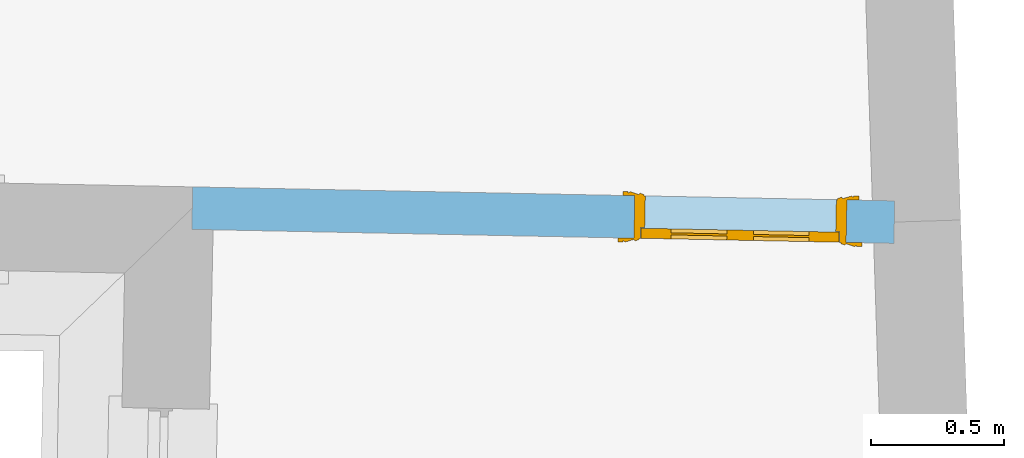
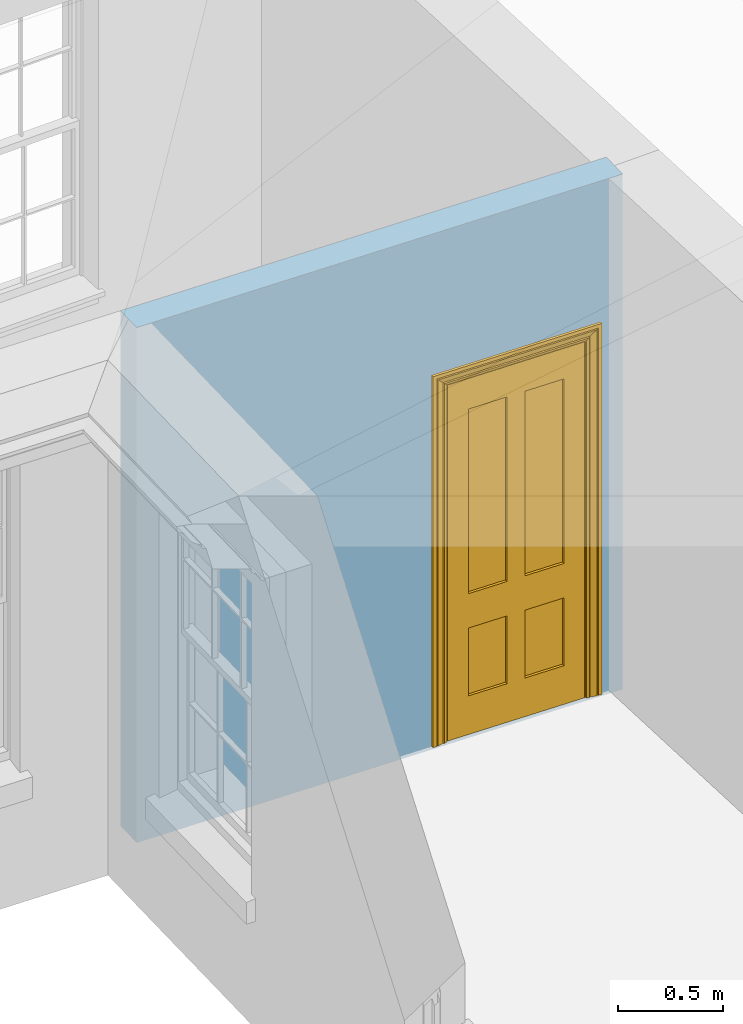
# One storey, part 6 of 11: 1 door, 1 opening, plus 1 element that does not belong to this part.
"""IFC2X3 building model written with IfcOpenShell, lengths in metres."""

import ifcopenshell
import ifcopenshell.guid

model = None  # the IFC model being written
_history = None  # IfcOwnerHistory: only IFC2X3 demands one
_inside = {}  # id of a spatial element -> (the spatial element, [elements in it])
_under = {}  # id of a project, library or spatial element -> (it, [spatial elements below it])
_declared = {}  # id of a project -> (the project, [libraries it declares])
_typed = {}  # id of a type object -> (the type object, [elements of that type])
_made_of = {}  # id of a material, layer set ... -> (it, [elements and type objects made of it])


def new_model(schema):
    """Start an empty IFC model of exactly this schema.

    Asked for "IFC4X3", IfcOpenShell would pick the latest addendum, in which some entities
    have other attributes; the version numbers below select the first issue.
    IFC2X3 requires an IfcOwnerHistory on every rooted entity: one is made here for all.
    """
    global model, _history
    if schema == "IFC4X3":
        model = ifcopenshell.file(schema_version=(4, 3, 0, 0))
    else:
        model = ifcopenshell.file(schema=schema)
    _inside.clear()
    _under.clear()
    _declared.clear()
    _typed.clear()
    _made_of.clear()
    _history = None
    if model.schema == "IFC2X3":
        org = make("IfcOrganization", Name="unknown")
        user = make(
            "IfcPersonAndOrganization",
            ThePerson=make("IfcPerson", FamilyName="unknown"),
            TheOrganization=org,
        )
        app = make(
            "IfcApplication",
            ApplicationDeveloper=org,
            Version="unknown",
            ApplicationFullName="unknown",
            ApplicationIdentifier="unknown",
        )
        _history = make(
            "IfcOwnerHistory",
            OwningUser=user,
            OwningApplication=app,
            ChangeAction="ADDED",
            CreationDate=0,
        )
    return model


def make(cls, **values):
    """One entity of the class cls with the attributes given. An attribute that is None is left unset."""
    return model.create_entity(
        cls, **{name: value for name, value in values.items() if value is not None}
    )


def rooted(cls, **values):
    """An entity with a GlobalId (a new one), such as an element, a storey or a relation."""
    return make(cls, GlobalId=ifcopenshell.guid.new(), OwnerHistory=_history, **values)


def si_unit(unit_type, name, prefix=None):
    """IfcSIUnit, for example si_unit("LENGTHUNIT", "METRE", prefix="MILLI")."""
    return make("IfcSIUnit", UnitType=unit_type, Prefix=prefix, Name=name)


def assignment(units):
    """IfcUnitAssignment: the units of a project."""
    return None if units is None else make("IfcUnitAssignment", Units=units)


def point(xyz):
    """IfcCartesianPoint."""
    return None if xyz is None else make("IfcCartesianPoint", Coordinates=xyz)


def direction(xyz):
    """IfcDirection."""
    return None if xyz is None else make("IfcDirection", DirectionRatios=xyz)


def frame(location, z_axis=None, x_axis=None):
    """IfcAxis2Placement3D, a coordinate frame: its origin and axes. An axis left out is left unset."""
    return make(
        "IfcAxis2Placement3D",
        Location=point(location),
        Axis=direction(z_axis),
        RefDirection=direction(x_axis),
    )


def origin():
    """The frame at (0, 0, 0) with its axes left unset."""
    return frame((0.0, 0.0, 0.0))


def place(relative_to, where):
    """IfcLocalPlacement: puts the frame where relative to a parent placement (None: the world)."""
    return make(
        "IfcLocalPlacement", PlacementRelTo=relative_to, RelativePlacement=where
    )


def context(
    kind, dimensions, precision=None, world=None, true_north=None, identifier=None
):
    """IfcGeometricRepresentationContext, for example the 3D "Model" context."""
    return make(
        "IfcGeometricRepresentationContext",
        ContextIdentifier=identifier,
        ContextType=kind,
        CoordinateSpaceDimension=dimensions,
        Precision=precision,
        WorldCoordinateSystem=world,
        TrueNorth=true_north,
    )


def subcontext(parent, identifier, kind, view, scale=None):
    """IfcGeometricRepresentationSubContext, for example "Body" below "Model"."""
    return make(
        "IfcGeometricRepresentationSubContext",
        ContextIdentifier=identifier,
        ContextType=kind,
        ParentContext=parent,
        TargetScale=scale,
        TargetView=view,
    )


def project(units=None, contexts=None):
    """IfcProject with its units and contexts."""
    return rooted(
        "IfcProject",
        Name="project",
        RepresentationContexts=contexts,
        UnitsInContext=assignment(units),
    )


def spatial(cls, under=None, at=None, **own):
    """A site, building, storey or space (cls), placed at a placement, below another one or the project."""
    s = rooted(cls, ObjectPlacement=at, **own)
    if under is not None:
        _under.setdefault(under.id(), (under, []))[1].append(s)
    return s


def polyline(points):
    """IfcPolyline through the points."""
    return make("IfcPolyline", Points=[point(p) for p in points])


def outline(outer, holes=None, kind="AREA"):
    """IfcArbitraryClosedProfileDef: a profile drawn as a closed curve; with holes, ...WithVoids."""
    if holes is None:
        return make("IfcArbitraryClosedProfileDef", ProfileType=kind, OuterCurve=outer)
    return make(
        "IfcArbitraryProfileDefWithVoids",
        ProfileType=kind,
        OuterCurve=outer,
        InnerCurves=holes,
    )


def extrude(swept, where, along, depth):
    """IfcExtrudedAreaSolid: the profile swept, set in the frame where, extruded along a direction by depth."""
    return make(
        "IfcExtrudedAreaSolid",
        SweptArea=swept,
        Position=where,
        ExtrudedDirection=direction(along),
        Depth=depth,
    )


def faces_of(points, faces, orient=None, outer=None):
    """IfcFace entities. A face is a list of loops; a loop is a list of indices into points, from 0.

    orient and outer hold one flag for each loop. By default every Orientation is true, the
    first loop of a face is its IfcFaceOuterBound and the others are IfcFaceBound.
    """
    made = []
    for i, loops in enumerate(faces):
        bounds = []
        for j, loop in enumerate(loops):
            is_outer = j == 0 if outer is None else outer[i][j]
            bounds.append(
                make(
                    "IfcFaceOuterBound" if is_outer else "IfcFaceBound",
                    Bound=make("IfcPolyLoop", Polygon=[points[k] for k in loop]),
                    Orientation=True if orient is None else orient[i][j],
                )
            )
        made.append(make("IfcFace", Bounds=bounds))
    return made


def faceted_brep(points, faces, orient=None, outer=None, voids=None):
    """IfcFacetedBrep: a solid bounded by flat faces; with voids (closed shells), ...WithVoids."""
    shared = [point(p) for p in points]
    hull = make("IfcClosedShell", CfsFaces=faces_of(shared, faces, orient, outer))
    if voids is None:
        return make("IfcFacetedBrep", Outer=hull)
    return make(
        "IfcFacetedBrepWithVoids",
        Outer=hull,
        Voids=[
            make(cls, CfsFaces=faces_of(shared, fs, o, b)) for cls, fs, o, b in voids
        ],
    )


def shape(context_of_items, identifier, shape_type, items):
    """IfcShapeRepresentation: the items that make up one representation, for example the "Body"."""
    return make(
        "IfcShapeRepresentation",
        ContextOfItems=context_of_items,
        RepresentationIdentifier=identifier,
        RepresentationType=shape_type,
        Items=items,
    )


def material(Name=None, Category=None):
    """IfcMaterial."""
    return make("IfcMaterial", Name=Name, Category=Category)


def layer(
    of_material, thickness, ventilated=None, Name=None, Category=None, Priority=None
):
    """IfcMaterialLayer: one layer of a wall or slab, of a material (None: an air gap)."""
    return make(
        "IfcMaterialLayer",
        Material=of_material,
        LayerThickness=thickness,
        IsVentilated=ventilated,
        Name=Name,
        Category=Category,
        Priority=Priority,
    )


def layer_set(layers, Name=None):
    """IfcMaterialLayerSet."""
    return make("IfcMaterialLayerSet", MaterialLayers=layers, LayerSetName=Name)


def layer_usage(for_layer_set, set_direction, sense, offset, extent=None):
    """IfcMaterialLayerSetUsage: how a layer set lies in its element."""
    return make(
        "IfcMaterialLayerSetUsage",
        ForLayerSet=for_layer_set,
        LayerSetDirection=set_direction,
        DirectionSense=sense,
        OffsetFromReferenceLine=offset,
        ReferenceExtent=extent,
    )


def made_of(thing, what):
    """Note that an element or type object is made of a material, layer set ...; save() writes the relation."""
    if what is not None:
        _made_of.setdefault(what.id(), (what, []))[1].append(thing)
    return thing


def element(
    cls,
    number,
    at=None,
    inside=None,
    cuts=None,
    type_object=None,
    material=None,
    context=None,
    identifier="Body",
    shape_type=None,
    held_by="IfcProductDefinitionShape",
    body=None,
    shapes=None,
    **own,
):
    """One element of the class cls, such as IfcWall. Its Tag is "e" and its number.

    at: its placement. inside: the storey or other place that contains it. cuts: it is an
    opening in that element (IfcRelVoidsElement). A single representation is given by context,
    identifier, shape_type and body (its items); several are given by shapes. held_by: the class
    of the entity that holds the representations. save() writes the other relations.
    """
    e = rooted(cls, Tag="e%d" % number, ObjectPlacement=at, **own)
    if body is not None:
        shapes = [shape(context, identifier, shape_type, body)]
    if shapes is not None:
        e.Representation = make(held_by, Representations=shapes)
    if inside is not None:
        _inside.setdefault(inside.id(), (inside, []))[1].append(e)
    if cuts is not None:
        rooted(
            "IfcRelVoidsElement", RelatingBuildingElement=cuts, RelatedOpeningElement=e
        )
    if type_object is not None:
        _typed.setdefault(type_object.id(), (type_object, []))[1].append(e)
    return made_of(e, material)


def fill(opening, filler):
    """IfcRelFillsElement: the door or window that sits in an opening."""
    return rooted(
        "IfcRelFillsElement",
        RelatingOpeningElement=opening,
        RelatedBuildingElement=filler,
    )


def aggregate(whole, parts):
    """IfcRelAggregates: a whole, such as a stair, and the parts it consists of."""
    return rooted("IfcRelAggregates", RelatingObject=whole, RelatedObjects=parts)


def save(model, path):
    """Write the relations noted so far, then the file.

    IfcRelAggregates (storeys below a building ...), IfcRelContainedInSpatialStructure (elements
    in a storey), IfcRelDefinesByType, IfcRelAssociatesMaterial and IfcRelDeclares: one each for
    every whole, place, type object, material and project.
    """
    for whole, parts in _under.values():
        aggregate(whole, parts)
    for where, things in _inside.values():
        rooted(
            "IfcRelContainedInSpatialStructure",
            RelatedElements=things,
            RelatingStructure=where,
        )
    for kind, things in _typed.values():
        rooted("IfcRelDefinesByType", RelatedObjects=things, RelatingType=kind)
    for what, things in _made_of.values():
        rooted("IfcRelAssociatesMaterial", RelatedObjects=things, RelatingMaterial=what)
    for by, libraries in _declared.values():
        rooted("IfcRelDeclares", RelatingContext=by, RelatedDefinitions=libraries)
    model.write(path)


model = new_model("IFC2X3")

# Units and contexts
model_context = context("Model", 3, world=origin())
body_context = subcontext(model_context, "Body", "Model", "MODEL_VIEW")
ifc_project = project(units=[si_unit("PLANEANGLEUNIT", "RADIAN"), si_unit("MASSUNIT", "GRAM", prefix="KILO"), si_unit("FORCEUNIT", "NEWTON", prefix="KILO"), si_unit("LENGTHUNIT", "METRE")], contexts=[model_context])

# Site, building, storey
site_placement = place(None, origin())
site = spatial("IfcSite", under=ifc_project, at=site_placement, CompositionType="ELEMENT")
building_placement = place(None, origin())
building = spatial("IfcBuilding", under=site, at=building_placement, Name="Building plot-10", CompositionType="ELEMENT")
storey_placement = place(None, frame((0.0, 0.0, 4.6)))
storey = spatial("IfcBuildingStorey", under=building, at=storey_placement, Name="Floor 1", CompositionType="ELEMENT", Elevation=4.6)

# Wall, opening, door
ifc_material = material(Name="Masonry")
ifc_layer = layer(ifc_material, 0.16, ventilated=False)
ifc_layer_set = layer_set([ifc_layer], Name="My Wall")
ifc_layer_usage = layer_usage(ifc_layer_set, "AXIS2", "NEGATIVE", 0.08)
wall_placement = place(storey_placement, origin())
wall = element("IfcWallStandardCase", 1, at=wall_placement, inside=storey, material=ifc_layer_usage, Name="interior", context=body_context, shape_type="SweptSolid", body=[
    extrude(outline(polyline([(53.5679253721729, 17.0442968217982), (53.5711131476829, 17.204265062669), (50.9254174036142, 17.2569873033702), (50.9222296281042, 17.0970190624994), (53.5679253721729, 17.0442968217982)])), origin(), (0.0, 0.0, 1.0), 3.0),
])
opening_placement = place(storey_placement, frame((0.0, 0.0, 0.0199999999999996)))
opening = element("IfcOpeningElement", 2, at=opening_placement, cuts=wall, Name="Opening", ObjectType="Opening", context=body_context, shape_type="SweptSolid", body=[
    extrude(outline(polyline([(53.3911488767032, 17.2078513101177), (52.5913076723492, 17.2237901876675), (52.5881198968393, 17.0638219467967), (53.3879611011933, 17.0478830692469), (53.3911488767032, 17.2078513101177)])), origin(), (0.0, 0.0, 1.0), 2.1),
])
door_placement = place(storey_placement, frame((53.3895549889482, 17.1278671896823, 0.0199999999999996), z_axis=(0.0, 0.0, 1.0), x_axis=(-0.799841204353996, 0.0159388775497824, 0.0)))
door = element("IfcDoor", 3, at=door_placement, inside=storey, Name="toilet inside door", OverallHeight=2.1, OverallWidth=0.8, context=body_context, shape_type="Brep", held_by="IfcProductRepresentation", body=[
    faceted_brep([(0.773, 0.08, 1.895), (0.66, 0.08, 1.895), (0.66, 0.08, 2.073), (0.773, 0.08, 2.073), (0.773, 0.08, 0.82), (0.66, 0.08, 0.82), (0.45, 0.08, 1.895), (0.45, 0.08, 2.073), (0.773, 0.08, 0.62), (0.66, 0.08, 0.62), (0.66, 0.065, 0.82), (0.66, 0.065, 1.895), (0.45, 0.065, 1.895), (0.35, 0.08, 1.895), (0.35, 0.08, 2.073), (0.773, 0.08, 0.225), (0.66, 0.08, 0.225), (0.45, 0.08, 0.62), (0.45, 0.08, 0.82), (0.45, 0.065, 0.82), (0.35, 0.08, 0.82), (0.14, 0.08, 2.073), (0.14, 0.08, 1.895), (0.773, 0.08, 0.0), (0.66, 0.08, 0.0), (0.66, 0.065, 0.225), (0.66, 0.065, 0.62), (0.45, 0.065, 0.62), (0.35, 0.08, 0.62), (0.35, 0.065, 0.82), (0.35, 0.065, 1.895), (0.14, 0.065, 1.895), (0.027, 0.08, 2.073), (0.027, 0.08, 1.895), (0.773, 0.042, 0.0), (0.66, 0.042, 0.0), (0.45, 0.08, 0.0), (0.45, 0.08, 0.225), (0.45, 0.065, 0.225), (0.35, 0.08, 0.225), (0.14, 0.08, 0.82), (0.14, 0.08, 0.62), (0.14, 0.065, 0.82), (0.027, 0.08, 0.82), (0.773, 0.042, 0.225), (0.66, 0.042, 0.225), (0.45, 0.042, 0.0), (0.35, 0.08, 0.0), (0.35, 0.065, 0.225), (0.35, 0.065, 0.62), (0.14, 0.065, 0.62), (0.027, 0.08, 0.62), (0.773, 0.042, 0.62), (0.66, 0.042, 0.62), (0.45, 0.042, 0.225), (0.35, 0.042, 0.0), (0.14, 0.08, 0.225), (0.14, 0.08, 0.0), (0.14, 0.065, 0.225), (0.027, 0.08, 0.225), (0.773, 0.042, 0.82), (0.66, 0.042, 0.82), (0.66, 0.057, 0.62), (0.66, 0.057, 0.225), (0.45, 0.057, 0.225), (0.35, 0.042, 0.225), (0.14, 0.042, 0.0), (0.027, 0.08, 0.0), (0.773, 0.042, 1.895), (0.66, 0.042, 1.895), (0.45, 0.042, 0.62), (0.45, 0.042, 0.82), (0.45, 0.057, 0.62), (0.35, 0.042, 0.62), (0.14, 0.042, 0.225), (0.027, 0.042, 0.0), (0.773, 0.042, 2.073), (0.66, 0.042, 2.073), (0.66, 0.057, 1.895), (0.66, 0.057, 0.82), (0.45, 0.057, 0.82), (0.35, 0.042, 0.82), (0.35, 0.057, 0.62), (0.35, 0.057, 0.225), (0.14, 0.057, 0.225), (0.027, 0.042, 0.225), (0.45, 0.042, 1.895), (0.45, 0.042, 2.073), (0.45, 0.057, 1.895), (0.35, 0.042, 1.895), (0.14, 0.042, 0.82), (0.14, 0.042, 0.62), (0.14, 0.057, 0.62), (0.027, 0.042, 0.62), (0.35, 0.042, 2.073), (0.35, 0.057, 1.895), (0.35, 0.057, 0.82), (0.14, 0.057, 0.82), (0.027, 0.042, 0.82), (0.14, 0.042, 2.073), (0.14, 0.042, 1.895), (0.14, 0.057, 1.895), (0.027, 0.042, 1.895), (0.027, 0.042, 2.073), (0.02, 0.085, 0.0), (0.005, 0.09, 0.0), (0.005, 0.09, 2.095), (0.02, 0.085, 2.08), (0.02, 0.08, 0.0), (0.0, 0.085, 0.0), (0.0, 0.085, 2.1), (0.795, 0.09, 2.095), (0.78, 0.085, 2.08), (0.02, 0.08, 2.08), (0.0, 0.08, 0.0), (-0.032, 0.095, 0.0), (-0.032, 0.095, 2.132), (0.8, 0.085, 2.1), (0.795, 0.09, 0.0), (0.78, 0.085, 0.0), (0.78, 0.08, 2.08), (0.04, 0.04, 0.0), (0.025, 0.04, 0.0), (0.025, 0.04, 2.075), (0.04, 0.04, 2.06), (-0.04, 0.09, 0.0), (-0.04, 0.09, 2.14), (0.832, 0.095, 2.132), (0.8, 0.085, 0.0), (0.78, 0.08, 0.0), (0.8, 0.08, 0.0), (0.86, 0.08, 0.0), (0.86, 0.08, 2.16), (0.8, 0.08, 2.1), (-0.06, 0.08, 2.16), (0.0, 0.08, 2.1), (-0.06, 0.08, 0.0), (-0.04, 0.095, 0.0), (-0.04, 0.095, 2.14), (0.84, 0.09, 2.14), (0.832, 0.095, 0.0), (0.84, 0.09, 0.0), (0.86, 0.095, 0.0), (0.86, 0.095, 2.16), (-0.06, 0.095, 2.16), (-0.06, 0.095, 0.0), (0.84, 0.095, 0.0), (0.84, 0.095, 2.14), (-0.025, -0.095, 0.0), (-0.025, -0.09, 0.0), (-0.025, -0.09, 2.125), (-0.025, -0.095, 2.125), (-0.017, -0.095, 0.0), (-0.017, -0.095, 2.117), (0.825, -0.09, 2.125), (0.825, -0.095, 2.125), (0.825, -0.095, 0.0), (0.845, -0.095, 0.0), (-0.045, -0.095, 2.145), (-0.045, -0.095, 0.0), (0.845, -0.095, 2.145), (0.015, -0.085, 0.0), (0.015, -0.085, 2.085), (0.817, -0.095, 2.117), (0.825, -0.09, 0.0), (0.845, -0.08, 0.0), (0.845, -0.08, 2.145), (-0.045, -0.08, 2.145), (-0.045, -0.08, 0.0), (0.02, -0.09, 0.0), (0.02, -0.09, 2.08), (0.785, -0.085, 2.085), (0.817, -0.095, 0.0), (0.8, -0.08, 0.0), (0.8, -0.08, 2.1), (0.0, -0.08, 2.1), (0.0, -0.08, 0.0), (0.035, -0.085, 0.0), (0.035, -0.085, 2.065), (0.78, -0.09, 2.08), (0.785, -0.085, 0.0), (0.775, 0.04, 2.075), (0.76, 0.04, 2.06), (0.035, -0.08, 2.065), (0.035, -0.08, 0.0), (0.765, -0.085, 2.065), (0.78, -0.09, 0.0), (0.765, -0.08, 0.0), (0.765, -0.08, 2.065), (0.765, -0.085, 0.0), (0.04, -0.08, 2.06), (0.04, -0.08, 0.0), (0.76, -0.08, 2.06), (0.76, -0.08, 0.0), (0.76, 0.04, 0.0), (0.775, 0.04, 0.0), (0.025, 0.08, 0.0), (0.025, 0.08, 2.075), (0.775, 0.08, 0.0), (0.775, 0.08, 2.075)], [[[0, 1, 2, 3]], [[1, 0, 4, 5]], [[1, 6, 7, 2]], [[8, 9, 5, 4]], [[1, 5, 10, 11]], [[6, 1, 11, 12]], [[6, 13, 14, 7]], [[15, 16, 9, 8]], [[9, 17, 18, 5]], [[5, 18, 19, 10]], [[10, 19, 12, 11]], [[18, 6, 12, 19]], [[18, 20, 13, 6]], [[21, 14, 13, 22]], [[23, 24, 16, 15]], [[9, 16, 25, 26]], [[17, 9, 26, 27]], [[17, 28, 20, 18]], [[13, 20, 29, 30]], [[22, 13, 30, 31]], [[32, 21, 22, 33]], [[34, 35, 24, 23]], [[24, 36, 37, 16]], [[16, 37, 38, 25]], [[25, 38, 27, 26]], [[37, 17, 27, 38]], [[37, 39, 28, 17]], [[40, 20, 28, 41]], [[20, 40, 42, 29]], [[31, 30, 29, 42]], [[40, 22, 31, 42]], [[33, 22, 40, 43]], [[35, 34, 44, 45]], [[35, 46, 36, 24]], [[36, 47, 39, 37]], [[28, 39, 48, 49]], [[41, 28, 49, 50]], [[43, 40, 41, 51]], [[45, 44, 52, 53]], [[46, 35, 45, 54]], [[46, 55, 47, 36]], [[56, 39, 47, 57]], [[39, 56, 58, 48]], [[50, 49, 48, 58]], [[56, 41, 50, 58]], [[51, 41, 56, 59]], [[53, 52, 60, 61]], [[45, 53, 62, 63]], [[54, 45, 63, 64]], [[55, 46, 54, 65]], [[55, 66, 57, 47]], [[59, 56, 57, 67]], [[61, 60, 68, 69]], [[70, 53, 61, 71]], [[53, 70, 72, 62]], [[72, 64, 63, 62]], [[70, 54, 64, 72]], [[65, 54, 70, 73]], [[65, 74, 66, 55]], [[67, 57, 66, 75]], [[69, 68, 76, 77]], [[61, 69, 78, 79]], [[71, 61, 79, 80]], [[73, 70, 71, 81]], [[65, 73, 82, 83]], [[74, 65, 83, 84]], [[74, 85, 75, 66]], [[86, 69, 77, 87]], [[69, 86, 88, 78]], [[88, 80, 79, 78]], [[86, 71, 80, 88]], [[81, 71, 86, 89]], [[73, 81, 90, 91]], [[73, 91, 92, 82]], [[83, 82, 92, 84]], [[91, 74, 84, 92]], [[91, 93, 85, 74]], [[89, 86, 87, 94]], [[81, 89, 95, 96]], [[90, 81, 96, 97]], [[90, 98, 93, 91]], [[94, 99, 100, 89]], [[89, 100, 101, 95]], [[101, 97, 96, 95]], [[100, 90, 97, 101]], [[100, 102, 98, 90]], [[99, 103, 102, 100]], [[32, 103, 99, 21]], [[102, 103, 32, 33]], [[98, 102, 33, 43]], [[21, 99, 94, 14]], [[94, 87, 7, 14]], [[7, 87, 77, 2]], [[76, 3, 2, 77]], [[43, 51, 93, 98]], [[51, 59, 85, 93]], [[67, 75, 85, 59]], [[34, 23, 15, 44]], [[44, 15, 8, 52]], [[52, 8, 4, 60]], [[0, 68, 60, 4]], [[0, 3, 76, 68]], [[104, 105, 106, 107]], [[104, 108, 109, 105]], [[105, 109, 110, 106]], [[107, 106, 111, 112]], [[107, 113, 108, 104]], [[114, 109, 108]], [[109, 115, 116, 110]], [[106, 110, 117, 111]], [[112, 111, 118, 119]], [[113, 107, 112, 120]], [[121, 122, 123, 124]], [[115, 109, 114, 125]], [[115, 125, 126, 116]], [[110, 116, 127, 117]], [[111, 117, 128, 118]], [[118, 128, 129, 119]], [[120, 112, 119, 129]], [[130, 129, 128]], [[130, 131, 132, 133]], [[133, 132, 134, 135]], [[135, 134, 136, 114]], [[136, 125, 114]], [[125, 137, 138, 126]], [[116, 126, 139, 127]], [[117, 127, 140, 128]], [[141, 130, 128, 140]], [[131, 130, 141]], [[131, 142, 143, 132]], [[132, 143, 144, 134]], [[134, 144, 145, 136]], [[137, 125, 136, 145]], [[143, 142, 146]], [[143, 146, 147]], [[137, 145, 144]], [[143, 147, 138]], [[138, 137, 144]], [[143, 138, 144]], [[126, 138, 147, 139]], [[127, 139, 141, 140]], [[142, 131, 141, 146]], [[139, 147, 146, 141]], [[148, 149, 150, 151]], [[149, 152, 153, 150]], [[151, 150, 154, 155]], [[155, 156, 157]], [[158, 159, 148]], [[158, 148, 151]], [[155, 157, 160]], [[158, 151, 155]], [[155, 160, 158]], [[152, 161, 162, 153]], [[150, 153, 163, 154]], [[155, 154, 164, 156]], [[156, 164, 165, 157]], [[157, 165, 166, 160]], [[160, 166, 167, 158]], [[158, 167, 168, 159]], [[161, 169, 170, 162]], [[153, 162, 171, 163]], [[154, 163, 172, 164]], [[165, 164, 173]], [[165, 173, 174, 166]], [[166, 174, 175, 167]], [[167, 175, 176, 168]], [[169, 177, 178, 170]], [[162, 170, 179, 171]], [[163, 171, 180, 172]], [[172, 180, 173, 164]], [[124, 123, 181, 182]], [[183, 178, 177, 184]], [[170, 178, 185, 179]], [[171, 179, 186, 180]], [[187, 173, 180]], [[185, 188, 187, 189]], [[188, 185, 178, 183]], [[179, 185, 189, 186]], [[189, 187, 180, 186]], [[190, 183, 184, 191]], [[192, 188, 183, 190]], [[191, 184, 122, 121]], [[124, 190, 191, 121]], [[193, 187, 188, 192]], [[182, 192, 190, 124]], [[184, 176, 122]], [[194, 195, 187, 193]], [[192, 182, 194, 193]], [[161, 176, 184]], [[114, 108, 122, 176]], [[173, 187, 195]], [[152, 149, 176, 161]], [[169, 161, 184, 177]], [[196, 122, 108]], [[176, 175, 135, 114]], [[173, 195, 129, 130]], [[176, 149, 168]], [[123, 122, 196, 197]], [[196, 108, 113, 197]], [[175, 174, 133, 135]], [[198, 129, 195]], [[133, 174, 173, 130]], [[159, 168, 149, 148]], [[181, 123, 197, 199]], [[197, 113, 120, 199]], [[199, 120, 129, 198]], [[195, 181, 199, 198]], [[195, 194, 182, 181]]]),
])
fill(opening, door)

save(model, "model.ifc")
